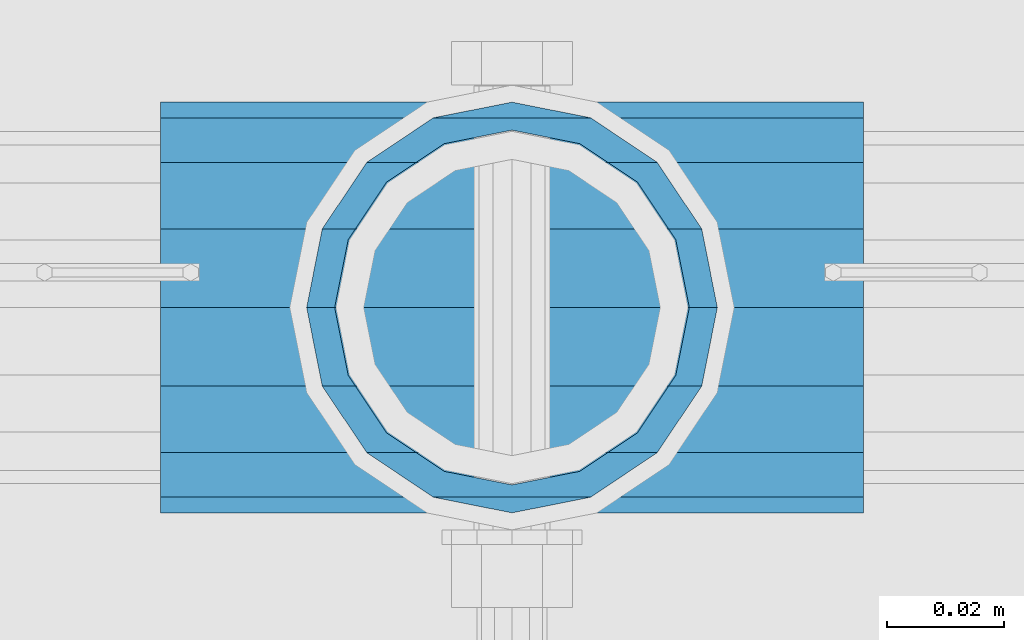
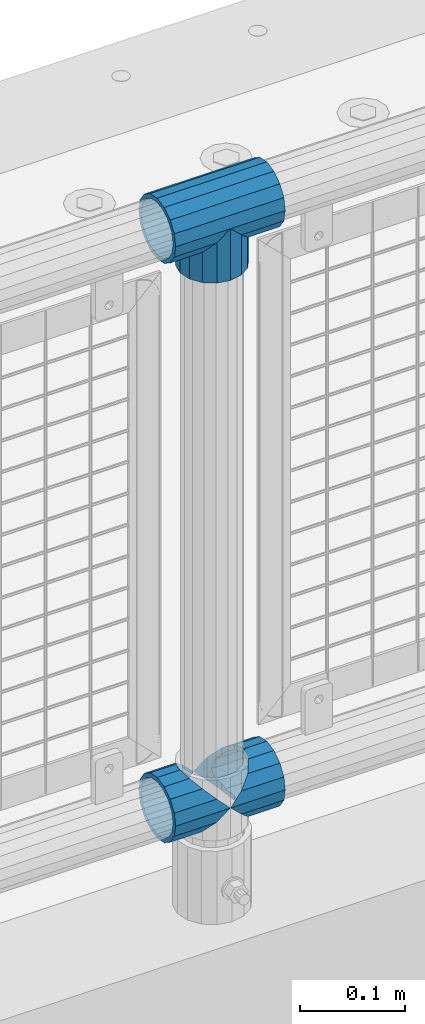
# One storey, part 119 of 208: 4 beams.
"""IFC2X3 building model written with IfcOpenShell, lengths in millimetres."""

from ifc_helpers import new_model, si_unit, frame, origin_with_axes, place, context, subcontext, project, spatial, faceted_brep, material, type_object, element, save


model = new_model("IFC2X3")

# Units and contexts
model_context = context("Model", 3, precision=1e-05, world=origin_with_axes())
body_context = subcontext(model_context, "Body", "Model", "MODEL_VIEW")
ifc_project = project(units=[si_unit("LENGTHUNIT", "METRE", prefix="MILLI"), si_unit("AREAUNIT", "SQUARE_METRE"), si_unit("VOLUMEUNIT", "CUBIC_METRE"), si_unit("MASSUNIT", "GRAM", prefix="KILO"), si_unit("TIMEUNIT", "SECOND"), si_unit("PLANEANGLEUNIT", "RADIAN"), si_unit("SOLIDANGLEUNIT", "STERADIAN"), si_unit("THERMODYNAMICTEMPERATUREUNIT", "DEGREE_CELSIUS"), si_unit("LUMINOUSINTENSITYUNIT", "LUMEN")], contexts=[model_context])

# Site, building, storey
site_placement = place(None, origin_with_axes())
site = spatial("IfcSite", under=ifc_project, at=site_placement, CompositionType="ELEMENT")
building_placement = place(site_placement, origin_with_axes())
building = spatial("IfcBuilding", under=site, at=building_placement, Name="Standard", CompositionType="ELEMENT")
storey_placement = place(building_placement, origin_with_axes())
storey = spatial("IfcBuildingStorey", under=building, at=storey_placement, Name="Undefined", CompositionType="ELEMENT", Elevation=0.0)

# Beams
ifc_material = material(Name="Misc_Undefined")
beam_type = type_object("IfcBeamType", PredefinedType="NOTDEFINED")
beam_1_placement = place(storey_placement, frame((-40229.0, 4664.5, 969.849999999999), z_axis=(0.0, 1.0, 0.0), x_axis=(0.0, 0.0, -1.0)))
element("IfcBeam", 1, at=beam_1_placement, inside=storey, type_object=beam_type, material=ifc_material, context=body_context, shape_type="Brep", body=[
    faceted_brep([(0.0, 0.0, 35.1499999999996), (13.4513226476338, 13.4513226476329, 32.4743655677721), (13.4513226476338, -13.4513226476329, 32.4743655677721), (32.4743655677739, -32.4743655677717, -13.4513226476329), (32.4743655677739, -26.8123795176766, -13.4513226476329), (27.1226768591077, -21.4606908090117, -21.4606908090118), (24.8548033587067, -16.3810424080039, -24.8548033587067), (24.8548033587067, -24.8548033587072, -24.8548033587067), (13.4513226476338, -13.4513226476329, -32.4743655677721), (13.4513226476338, 13.4513226476329, -32.4743655677721), (0.0, 0.0, -35.1499999999996), (20.0882031229849, -11.6144421722805, -28.0397438117179), (16.6306603983685, 0.0, -30.3500000000004), (20.0882031229849, 11.6144421722805, -28.0397438117179), (24.8548033587067, 16.3810424080023, -24.8548033587067), (24.8548033587067, 24.8548033587072, -24.8548033587067), (32.4743655677739, 26.8123795176755, -13.4513226476329), (32.4743655677739, 32.4743655677717, -13.4513226476329), (27.1226768591077, 21.4606908090117, -21.4606908090118), (35.1500000000015, 30.35, 0.0), (35.1500000000015, 35.15, 0.0), (32.8397438117172, 28.0397438117175, -11.6144421722802), (32.8397438117172, 28.0397438117175, 11.6144421722802), (32.4743655677739, 26.812379517676, 13.4513226476329), (32.4743655677739, 32.4743655677717, 13.4513226476329), (27.1226768591005, 21.4606908090117, 21.4606908090118), (24.8548033587067, 16.3810424080032, 24.8548033587067), (24.8548033587067, 24.8548033587072, 24.8548033587067), (20.0882031229921, 11.6144421722805, 28.0397438117179), (16.6306603983685, 0.0, 30.3500000000004), (20.0882031229921, -11.6144421722805, 28.0397438117179), (24.8548033587067, -16.3810424080039, 24.8548033587067), (24.8548033587067, -24.8548033587072, 24.8548033587067), (27.1226768591005, -21.4606908090117, 21.4606908090118), (32.4743655677739, -26.8123795176755, 13.4513226476329), (32.4743655677739, -32.4743655677717, 13.4513226476329), (32.8397438117172, -28.0397438117175, 11.6144421722802), (35.1500000000015, -30.35, 0.0), (35.1500000000015, -35.1499999999996, 0.0), (32.8397438117172, -28.0397438117175, -11.6144421722802), (60.1500000000015, -24.8548033587072, -24.8548033587067), (60.1500000000015, -32.4743655677717, -13.4513226476329), (60.1500000000015, -13.4513226476329, -32.4743655677721), (60.1500000000015, 0.0, -35.1499999999996), (60.1500000000015, 13.4513226476329, -32.4743655677721), (60.1500000000015, 24.8548033587072, -24.8548033587067), (60.1500000000015, 32.4743655677717, -13.4513226476329), (60.1500000000015, 35.15, 0.0), (60.1500000000015, 32.4743655677717, 13.4513226476329), (60.1500000000015, 24.8548033587072, 24.8548033587067), (60.1500000000015, 13.4513226476329, 32.4743655677721), (60.1500000000015, 0.0, 35.1499999999996), (60.1500000000015, -13.4513226476329, 32.4743655677721), (60.1500000000015, -24.8548033587072, 24.8548033587067), (60.1500000000015, -32.4743655677717, 13.4513226476329), (60.1500000000015, -35.15, 0.0), (60.1500000000015, -21.4606908090117, 21.4606908090118), (60.1500000000015, -11.6144421722805, 28.0397438117179), (60.1500000000015, 0.0, 30.3500000000004), (60.1500000000015, 11.6144421722805, 28.0397438117179), (60.1500000000015, 21.4606908090117, 21.4606908090118), (60.1500000000015, 28.0397438117175, 11.6144421722802), (60.1500000000015, 30.35, 0.0), (60.1500000000015, 28.0397438117175, -11.6144421722802), (60.1500000000015, 21.4606908090117, -21.4606908090118), (60.1500000000015, 11.6144421722805, -28.0397438117179), (60.1500000000015, 0.0, -30.3500000000004), (60.1500000000015, -11.6144421722805, -28.0397438117179), (60.1500000000015, -21.4606908090117, -21.4606908090118), (60.1500000000015, -28.0397438117175, -11.6144421722802), (60.1500000000015, -30.35, 0.0), (60.1500000000015, -28.0397438117175, 11.6144421722802)], [[[0, 1, 2]], [[3, 4, 5, 6, 7]], [[8, 9, 10]], [[7, 6, 11, 12, 13, 14, 15, 9, 8]], [[16, 17, 15, 14, 18]], [[19, 20, 17, 16, 21]], [[22, 23, 24, 20, 19]], [[25, 26, 27, 24, 23]], [[2, 1, 27, 26, 28, 29, 30, 31, 32]], [[32, 31, 33, 34, 35]], [[35, 34, 36, 37, 38]], [[38, 37, 39, 4, 3]], [[40, 41, 3, 7]], [[42, 40, 7, 8]], [[43, 42, 8, 10]], [[44, 43, 10, 9]], [[45, 44, 9, 15]], [[46, 45, 15, 17]], [[47, 46, 17, 20]], [[48, 47, 20, 24]], [[49, 48, 24, 27]], [[50, 49, 27, 1]], [[51, 50, 1, 0]], [[52, 51, 0, 2]], [[53, 52, 2, 32]], [[54, 53, 32, 35]], [[55, 54, 35, 38]], [[41, 55, 38, 3]], [[40, 42, 43, 44, 45, 46, 47, 48, 49, 50, 51, 52, 53, 54, 55, 41], [56, 57, 58, 59, 60, 61, 62, 63, 64, 65, 66, 67, 68, 69, 70, 71]], [[71, 70, 37, 36]], [[33, 56, 71, 36, 34]], [[30, 57, 56, 33, 31]], [[58, 57, 30, 29]], [[59, 58, 29, 28]], [[60, 59, 28, 26, 25]], [[61, 60, 25, 23, 22]], [[62, 61, 22, 19]], [[63, 62, 19, 21]], [[18, 64, 63, 21, 16]], [[13, 65, 64, 18, 14]], [[66, 65, 13, 12]], [[67, 66, 12, 11]], [[68, 67, 11, 6, 5]], [[69, 68, 5, 4, 39]], [[70, 69, 39, 37]]]),
])
beam_2_placement = place(storey_placement, frame((-40289.15, 4664.5, 969.849999999999), z_axis=(0.0, 0.0, 1.0), x_axis=(1.0, 0.0, 0.0)))
element("IfcBeam", 2, at=beam_2_placement, inside=storey, type_object=beam_type, material=ifc_material, context=body_context, shape_type="Brep", body=[
    faceted_brep([(88.1897438117194, -11.6144421722802, -28.0397438117176), (88.1897438117194, -11.6144421722802, -32.8397438117178), (86.9623795176776, -13.4513226476329, -32.4743655677718), (81.6106908090114, -21.4606908090118, -27.1226768591068), (81.6106908090114, -21.4606908090118, -21.4606908090117), (76.531042407998, -24.8548033587067, -24.8548033587072), (71.7644421722835, -28.0397438117179, -20.0882031229861), (71.7644421722835, -28.0397438117179, -11.6144421722805), (60.1500000000015, -30.3500000000004, -16.6306603983687), (60.1500000000015, -30.35, 0.0), (48.5355578277195, -28.0397438117179, -20.0882031229861), (48.5355578277195, -28.0397438117179, -11.6144421722805), (43.7689575919976, -24.8548033587067, -24.8548033587072), (38.6893091909915, -21.4606908090118, -27.1226768591068), (38.6893091909915, -21.4606908090118, -21.4606908090117), (33.3376204823217, -13.4513226476329, -32.4743655677718), (32.1102561882835, -11.6144421722802, -32.8397438117178), (32.1102561882835, -11.6144421722802, -28.0397438117176), (29.8000000000029, 0.0, -35.15), (29.8000000000029, 0.0, -30.35), (32.1102561882835, 11.6144421722802, -32.8397438117175), (32.1102561882835, 11.6144421722802, -28.0397438117176), (33.3376204823217, 13.4513226476329, -32.4743655677718), (38.6893091909915, 21.4606908090118, -27.122676859108), (38.6893091909915, 21.4606908090118, -21.4606908090117), (43.7689575920012, 24.8548033587067, -24.8548033587072), (48.5355578277195, 28.0397438117179, -20.0882031229838), (48.5355578277195, 28.0397438117179, -11.6144421722805), (60.1500000000015, 30.3500000000004, -16.6306603983671), (60.1500000000015, 30.35, 0.0), (71.7644421722835, 28.0397438117179, -20.0882031229838), (71.7644421722835, 28.0397438117179, -11.6144421722805), (76.5310424080089, 24.8548033587067, -24.8548033587072), (81.6106908090114, 21.4606908090118, -27.122676859108), (81.6106908090114, 21.4606908090118, -21.4606908090117), (86.9623795176776, 13.4513226476329, -32.4743655677718), (88.1897438117194, 11.6144421722802, -32.8397438117175), (88.1897438117194, 11.6144421722802, -28.0397438117176), (90.5, 0.0, -35.15), (90.5, 0.0, -30.35), (0.0, -21.4606908090118, -21.4606908090136), (0.0, -28.0397438117179, -11.6144421722784), (0.0, -11.6144421722802, -28.0397438117143), (0.0, 0.0, -30.3499999999985), (0.0, 11.6144421722802, -28.0397438117143), (0.0, 21.4606908090118, -21.4606908090136), (0.0, 28.0397438117179, -11.6144421722784), (0.0, 30.3500000000004, 0.0), (0.0, 32.4743655677721, -13.4513226476338), (0.0, 35.1499999999996, 0.0), (120.299999999999, 35.1499999999996, 0.0), (120.299999999999, 32.4743655677721, -13.4513226476329), (0.0, 32.4743655677721, 13.4513226476338), (120.299999999999, 32.4743655677721, 13.4513226476329), (0.0, 24.8548033587067, 24.8548033587067), (120.299999999999, 24.8548033587067, 24.8548033587072), (0.0, 13.4513226476329, 32.4743655677739), (120.299999999999, 13.4513226476329, 32.4743655677718), (0.0, 0.0, 35.1499999999996), (120.299999999999, 0.0, 35.15), (0.0, -13.4513226476329, 32.4743655677739), (120.299999999999, -13.4513226476329, 32.4743655677718), (0.0, -24.8548033587067, 24.8548033587067), (120.299999999999, -24.8548033587067, 24.8548033587072), (0.0, -32.4743655677721, 13.4513226476338), (120.299999999999, -32.4743655677721, 13.4513226476329), (0.0, -35.1499999999996, 0.0), (120.299999999999, -35.1499999999996, 0.0), (0.0, -32.4743655677721, -13.4513226476338), (120.299999999999, -32.4743655677721, -13.4513226476329), (0.0, 24.8548033587067, -24.8548033587067), (0.0, 13.4513226476329, -32.4743655677739), (0.0, 0.0, -35.1499999999996), (0.0, -13.4513226476329, -32.4743655677739), (0.0, -24.8548033587067, -24.8548033587067), (0.0, 28.0397438117179, 11.6144421722784), (0.0, 21.4606908090118, 21.4606908090136), (0.0, 11.6144421722802, 28.0397438117143), (0.0, 0.0, 30.3499999999985), (0.0, -11.6144421722802, 28.0397438117143), (0.0, -21.4606908090118, 21.4606908090136), (0.0, -28.0397438117179, 11.6144421722784), (0.0, -30.3500000000004, 0.0), (120.299999999999, -30.3500000000004, 0.0), (120.299999999999, -28.0397438117179, -11.6144421722805), (120.299999999999, -21.4606908090118, -21.4606908090117), (120.299999999999, -11.6144421722802, -28.0397438117176), (120.299999999999, 0.0, -30.35), (120.299999999999, 21.4606908090118, -21.4606908090117), (120.299999999999, 28.0397438117179, -11.6144421722805), (120.299999999999, 11.6144421722802, -28.0397438117176), (120.299999999999, 30.3500000000004, 0.0), (120.299999999999, 28.0397438117179, 11.6144421722805), (120.299999999999, 21.4606908090118, 21.4606908090117), (120.299999999999, 11.6144421722802, 28.0397438117176), (120.299999999999, 0.0, 30.35), (120.299999999999, -11.6144421722802, 28.0397438117176), (120.299999999999, -21.4606908090118, 21.4606908090117), (120.299999999999, -28.0397438117179, 11.6144421722805), (120.299999999999, -24.8548033587067, -24.8548033587072), (120.299999999999, -13.4513226476329, -32.4743655677718), (120.299999999999, 0.0, -35.15), (120.299999999999, 13.4513226476329, -32.4743655677718), (120.299999999999, 24.8548033587067, -24.8548033587072)], [[[0, 1, 2, 3, 4]], [[4, 3, 5, 6, 7]], [[7, 6, 8, 9]], [[9, 8, 10, 11]], [[11, 10, 12, 13, 14]], [[14, 13, 15, 16, 17]], [[17, 16, 18, 19]], [[19, 18, 20, 21]], [[21, 20, 22, 23, 24]], [[24, 23, 25, 26, 27]], [[27, 26, 28, 29]], [[29, 28, 30, 31]], [[31, 30, 32, 33, 34]], [[34, 33, 35, 36, 37]], [[37, 36, 38, 39]], [[39, 38, 1, 0]], [[40, 41, 11, 14]], [[42, 40, 14, 17]], [[43, 42, 17, 19]], [[44, 43, 19, 21]], [[45, 44, 21, 24]], [[46, 45, 24, 27]], [[47, 46, 27, 29]], [[48, 49, 50, 51]], [[49, 52, 53, 50]], [[52, 54, 55, 53]], [[54, 56, 57, 55]], [[56, 58, 59, 57]], [[58, 60, 61, 59]], [[60, 62, 63, 61]], [[62, 64, 65, 63]], [[64, 66, 67, 65]], [[66, 68, 69, 67]], [[64, 62, 60, 58, 56, 54, 52, 49, 48, 70, 71, 72, 73, 74, 68, 66], [41, 40, 42, 43, 44, 45, 46, 47, 75, 76, 77, 78, 79, 80, 81, 82]], [[41, 82, 9, 11]], [[83, 84, 7, 9]], [[84, 85, 4, 7]], [[85, 86, 0, 4]], [[86, 87, 39, 0]], [[88, 89, 31, 34]], [[90, 88, 34, 37]], [[87, 90, 37, 39]], [[89, 91, 29, 31]], [[75, 47, 29, 91, 92]], [[76, 75, 92, 93]], [[77, 76, 93, 94]], [[78, 77, 94, 95]], [[79, 78, 95, 96]], [[80, 79, 96, 97]], [[81, 80, 97, 98]], [[9, 82, 81, 98, 83]], [[99, 100, 101, 102, 103, 51, 50, 53, 55, 57, 59, 61, 63, 65, 67, 69], [97, 96, 95, 94, 93, 92, 91, 89, 88, 90, 87, 86, 85, 84, 83, 98]], [[35, 102, 101, 38, 36]], [[32, 103, 102, 35, 33]], [[28, 26, 25, 70, 48, 51, 103, 32, 30]], [[22, 71, 70, 25, 23]], [[18, 72, 71, 22, 20]], [[73, 72, 18, 16, 15]], [[74, 73, 15, 13, 12]], [[99, 69, 68, 74, 12, 10, 8, 6, 5]], [[100, 99, 5, 3, 2]], [[101, 100, 2, 1, 38]]]),
])
beam_3_placement = place(storey_placement, frame((-40289.15, 4664.5, 298.17), z_axis=(0.0, 1.0, 0.0), x_axis=(1.0, 0.0, 0.0)))
element("IfcBeam", 3, at=beam_3_placement, inside=storey, type_object=beam_type, material=ifc_material, context=body_context, shape_type="Brep", body=[
    faceted_brep([(60.1500000000015, 0.0, -35.1499999999996), (46.6986773523677, 13.4513226476329, -32.4743655677721), (46.6986773523677, -13.4513226476329, -32.4743655677721), (33.0273231408937, 21.4606908090117, 21.4606908090118), (27.6756344322275, 26.812379517676, 13.4513226476329), (27.6756344322275, 32.4743655677717, 13.4513226476329), (35.2951966412948, 24.8548033587072, 24.8548033587067), (35.2951966412948, 16.3810424080032, 24.8548033587067), (27.3102561882915, 28.0397438117175, 11.6144421722802), (25.0, 30.35, 0.0), (25.0, 35.15, 0.0), (27.6756344322275, 26.8123795176755, -13.4513226476329), (27.6756344322275, 32.4743655677717, -13.4513226476329), (27.3102561882843, 28.0397438117175, -11.6144421722802), (35.2951966412948, 16.3810424080024, -24.8548033587067), (35.2951966412948, 24.8548033587072, -24.8548033587067), (33.0273231408864, 21.4606908090117, -21.4606908090118), (40.0617968770239, 11.6144421722805, -28.0397438117179), (43.5193396016402, 0.0, -30.3500000000004), (40.0617968770239, -11.6144421722805, -28.0397438117179), (35.2951966412948, -16.3810424080032, -24.8548033587067), (35.2951966412948, -24.8548033587072, -24.8548033587067), (33.0273231408864, -21.4606908090117, -21.4606908090118), (27.6756344322275, -26.812379517676, -13.4513226476329), (27.6756344322275, -32.4743655677717, -13.4513226476329), (27.3102561882843, -28.0397438117175, -11.6144421722802), (25.0, -30.35, 0.0), (25.0, -35.15, 0.0), (27.3102561882915, -28.0397438117175, 11.6144421722802), (27.6756344322275, -26.8123795176755, 13.4513226476329), (27.6756344322275, -32.4743655677717, 13.4513226476329), (33.0273231408937, -21.4606908090117, 21.4606908090118), (35.2951966412948, -16.3810424080032, 24.8548033587067), (35.2951966412948, -24.8548033587072, 24.8548033587067), (60.1500000000015, 0.0, 35.1499999999996), (46.6986773523677, -13.4513226476329, 32.4743655677721), (46.6986773523677, 13.4513226476329, 32.4743655677721), (40.0617968770093, -11.6144421722805, 28.0397438117179), (43.519339601633, 0.0, 30.3500000000004), (40.0617968770093, 11.6144421722805, 28.0397438117179), (0.0, -32.4743655677721, -13.4513226476338), (0.0, -24.8548033587067, -24.8548033587067), (0.0, -13.4513226476329, -32.4743655677739), (0.0, 0.0, -35.1499999999996), (0.0, 13.4513226476329, -32.4743655677739), (0.0, 24.8548033587067, -24.8548033587067), (0.0, 32.4743655677721, -13.4513226476338), (0.0, 35.1499999999996, 0.0), (0.0, 32.4743655677721, 13.4513226476338), (0.0, 24.8548033587067, 24.8548033587067), (0.0, 13.4513226476329, 32.4743655677739), (0.0, 0.0, 35.1499999999996), (0.0, -32.4743655677721, 13.4513226476338), (0.0, -35.1499999999996, 0.0), (0.0, -24.8548033587067, 24.8548033587067), (0.0, -13.4513226476329, 32.4743655677739), (0.0, -28.0397438117179, -11.6144421722784), (0.0, -21.4606908090118, -21.4606908090136), (0.0, -11.6144421722802, -28.0397438117143), (0.0, 0.0, -30.3499999999985), (0.0, 11.6144421722802, -28.0397438117143), (0.0, 21.4606908090118, -21.4606908090136), (0.0, 28.0397438117179, -11.6144421722784), (0.0, 30.3500000000004, 0.0), (0.0, 28.0397438117179, 11.6144421722784), (0.0, 21.4606908090118, 21.4606908090136), (0.0, 11.6144421722802, 28.0397438117143), (0.0, 0.0, 30.3499999999985), (0.0, -11.6144421722802, 28.0397438117143), (0.0, -21.4606908090118, 21.4606908090136), (0.0, -28.0397438117179, 11.6144421722784), (0.0, -30.3500000000004, 0.0)], [[[0, 1, 2]], [[3, 4, 5, 6, 7]], [[8, 9, 10, 5, 4]], [[11, 12, 10, 9, 13]], [[14, 15, 12, 11, 16]], [[2, 1, 15, 14, 17, 18, 19, 20, 21]], [[21, 20, 22, 23, 24]], [[24, 23, 25, 26, 27]], [[27, 26, 28, 29, 30]], [[30, 29, 31, 32, 33]], [[34, 35, 36]], [[33, 32, 37, 38, 39, 7, 6, 36, 35]], [[40, 41, 21, 24]], [[41, 42, 2, 21]], [[42, 43, 0, 2]], [[43, 44, 1, 0]], [[44, 45, 15, 1]], [[45, 46, 12, 15]], [[46, 47, 10, 12]], [[47, 48, 5, 10]], [[48, 49, 6, 5]], [[49, 50, 36, 6]], [[50, 51, 34, 36]], [[52, 53, 27, 30]], [[54, 52, 30, 33]], [[55, 54, 33, 35]], [[51, 55, 35, 34]], [[53, 40, 24, 27]], [[52, 54, 55, 51, 50, 49, 48, 47, 46, 45, 44, 43, 42, 41, 40, 53], [56, 57, 58, 59, 60, 61, 62, 63, 64, 65, 66, 67, 68, 69, 70, 71]], [[68, 67, 38, 37]], [[31, 69, 68, 37, 32]], [[28, 70, 69, 31, 29]], [[71, 70, 28, 26]], [[56, 71, 26, 25]], [[57, 56, 25, 23, 22]], [[58, 57, 22, 20, 19]], [[59, 58, 19, 18]], [[60, 59, 18, 17]], [[16, 61, 60, 17, 14]], [[13, 62, 61, 16, 11]], [[63, 62, 13, 9]], [[64, 63, 9, 8]], [[65, 64, 8, 4, 3]], [[66, 65, 3, 7, 39]], [[67, 66, 39, 38]]]),
])
beam_4_placement = place(storey_placement, frame((-40229.0, 4664.5, 298.17), z_axis=(0.0, 1.0, 0.0), x_axis=(1.0, 0.0, 0.0)))
element("IfcBeam", 4, at=beam_4_placement, inside=storey, type_object=beam_type, material=ifc_material, context=body_context, shape_type="Brep", body=[
    faceted_brep([(0.0, 0.0, 35.1499999999996), (13.4513226476338, 13.4513226476329, 32.4743655677721), (13.4513226476338, -13.4513226476329, 32.4743655677721), (32.4743655677739, -32.4743655677717, -13.4513226476329), (32.4743655677739, -26.8123795176766, -13.4513226476329), (27.1226768591077, -21.4606908090117, -21.4606908090118), (24.8548033587067, -16.3810424080039, -24.8548033587067), (24.8548033587067, -24.8548033587072, -24.8548033587067), (13.4513226476338, -13.4513226476329, -32.4743655677721), (13.4513226476338, 13.4513226476329, -32.4743655677721), (0.0, 0.0, -35.1499999999996), (20.0882031229849, -11.6144421722805, -28.0397438117179), (16.6306603983685, 0.0, -30.3500000000004), (20.0882031229849, 11.6144421722805, -28.0397438117179), (24.8548033587067, 16.3810424080023, -24.8548033587067), (24.8548033587067, 24.8548033587072, -24.8548033587067), (32.4743655677739, 26.8123795176755, -13.4513226476329), (32.4743655677739, 32.4743655677717, -13.4513226476329), (27.1226768591077, 21.4606908090117, -21.4606908090118), (35.1500000000015, 30.35, 0.0), (35.1500000000015, 35.15, 0.0), (32.8397438117172, 28.0397438117175, -11.6144421722802), (32.8397438117172, 28.0397438117175, 11.6144421722802), (32.4743655677739, 26.812379517676, 13.4513226476329), (32.4743655677739, 32.4743655677717, 13.4513226476329), (27.1226768591005, 21.4606908090117, 21.4606908090118), (24.8548033587067, 16.3810424080032, 24.8548033587067), (24.8548033587067, 24.8548033587072, 24.8548033587067), (20.0882031229921, 11.6144421722805, 28.0397438117179), (16.6306603983685, 0.0, 30.3500000000004), (20.0882031229921, -11.6144421722805, 28.0397438117179), (24.8548033587067, -16.3810424080039, 24.8548033587067), (24.8548033587067, -24.8548033587072, 24.8548033587067), (27.1226768591005, -21.4606908090117, 21.4606908090118), (32.4743655677739, -26.8123795176755, 13.4513226476329), (32.4743655677739, -32.4743655677717, 13.4513226476329), (32.8397438117172, -28.0397438117175, 11.6144421722802), (35.1500000000015, -30.35, 0.0), (35.1500000000015, -35.1499999999996, 0.0), (32.8397438117172, -28.0397438117175, -11.6144421722802), (60.1500000000015, -24.8548033587072, -24.8548033587067), (60.1500000000015, -32.4743655677717, -13.4513226476329), (60.1500000000015, -13.4513226476329, -32.4743655677721), (60.1500000000015, 0.0, -35.1499999999996), (60.1500000000015, 13.4513226476329, -32.4743655677721), (60.1500000000015, 24.8548033587072, -24.8548033587067), (60.1500000000015, 32.4743655677717, -13.4513226476329), (60.1500000000015, 35.15, 0.0), (60.1500000000015, 32.4743655677717, 13.4513226476329), (60.1500000000015, 24.8548033587072, 24.8548033587067), (60.1500000000015, 13.4513226476329, 32.4743655677721), (60.1500000000015, 0.0, 35.1499999999996), (60.1500000000015, -13.4513226476329, 32.4743655677721), (60.1500000000015, -24.8548033587072, 24.8548033587067), (60.1500000000015, -32.4743655677717, 13.4513226476329), (60.1500000000015, -35.15, 0.0), (60.1500000000015, -21.4606908090117, 21.4606908090118), (60.1500000000015, -11.6144421722805, 28.0397438117179), (60.1500000000015, 0.0, 30.3500000000004), (60.1500000000015, 11.6144421722805, 28.0397438117179), (60.1500000000015, 21.4606908090117, 21.4606908090118), (60.1500000000015, 28.0397438117175, 11.6144421722802), (60.1500000000015, 30.35, 0.0), (60.1500000000015, 28.0397438117175, -11.6144421722802), (60.1500000000015, 21.4606908090117, -21.4606908090118), (60.1500000000015, 11.6144421722805, -28.0397438117179), (60.1500000000015, 0.0, -30.3500000000004), (60.1500000000015, -11.6144421722805, -28.0397438117179), (60.1500000000015, -21.4606908090117, -21.4606908090118), (60.1500000000015, -28.0397438117175, -11.6144421722802), (60.1500000000015, -30.35, 0.0), (60.1500000000015, -28.0397438117175, 11.6144421722802)], [[[0, 1, 2]], [[3, 4, 5, 6, 7]], [[8, 9, 10]], [[7, 6, 11, 12, 13, 14, 15, 9, 8]], [[16, 17, 15, 14, 18]], [[19, 20, 17, 16, 21]], [[22, 23, 24, 20, 19]], [[25, 26, 27, 24, 23]], [[2, 1, 27, 26, 28, 29, 30, 31, 32]], [[32, 31, 33, 34, 35]], [[35, 34, 36, 37, 38]], [[38, 37, 39, 4, 3]], [[40, 41, 3, 7]], [[42, 40, 7, 8]], [[43, 42, 8, 10]], [[44, 43, 10, 9]], [[45, 44, 9, 15]], [[46, 45, 15, 17]], [[47, 46, 17, 20]], [[48, 47, 20, 24]], [[49, 48, 24, 27]], [[50, 49, 27, 1]], [[51, 50, 1, 0]], [[52, 51, 0, 2]], [[53, 52, 2, 32]], [[54, 53, 32, 35]], [[55, 54, 35, 38]], [[41, 55, 38, 3]], [[40, 42, 43, 44, 45, 46, 47, 48, 49, 50, 51, 52, 53, 54, 55, 41], [56, 57, 58, 59, 60, 61, 62, 63, 64, 65, 66, 67, 68, 69, 70, 71]], [[71, 70, 37, 36]], [[33, 56, 71, 36, 34]], [[30, 57, 56, 33, 31]], [[58, 57, 30, 29]], [[59, 58, 29, 28]], [[60, 59, 28, 26, 25]], [[61, 60, 25, 23, 22]], [[62, 61, 22, 19]], [[63, 62, 19, 21]], [[18, 64, 63, 21, 16]], [[13, 65, 64, 18, 14]], [[66, 65, 13, 12]], [[67, 66, 12, 11]], [[68, 67, 11, 6, 5]], [[69, 68, 5, 4, 39]], [[70, 69, 39, 37]]]),
])

save(model, "model.ifc")
